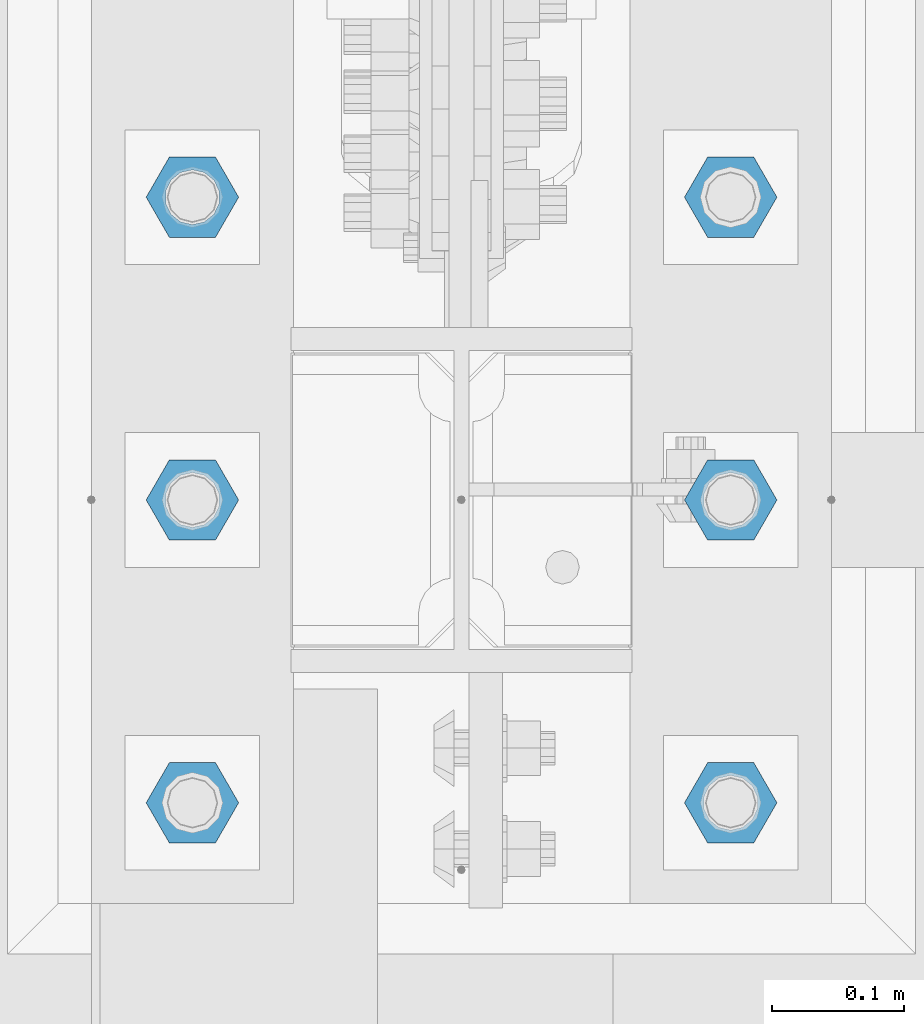
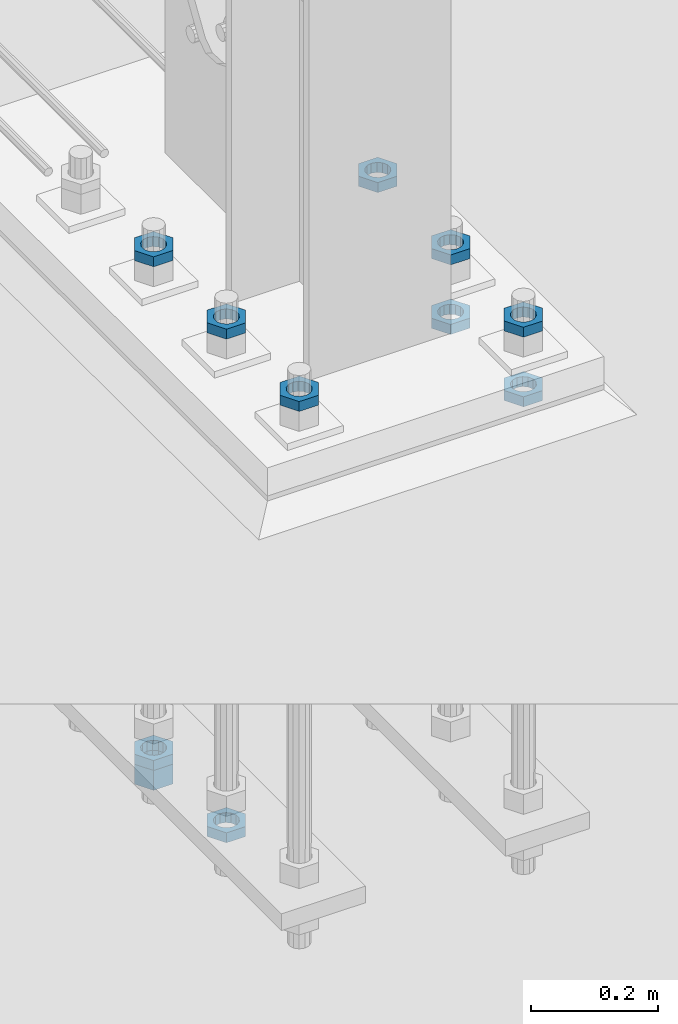
# One storey, part 2853 of 3843: 11 beams, 1 element without a shape of its own.
"""IFC2X3 building model written with IfcOpenShell, lengths in millimetres."""

from ifc_helpers import new_model, si_unit, frame, origin_with_axes, place, context, subcontext, project, spatial, faceted_brep, material, type_object, element, aggregate, save


model = new_model("IFC2X3")

# Units and contexts
model_context = context("Model", 3, precision=1e-05, world=origin_with_axes())
body_context = subcontext(model_context, "Body", "Model", "MODEL_VIEW")
ifc_project = project(units=[si_unit("LENGTHUNIT", "METRE", prefix="MILLI"), si_unit("AREAUNIT", "SQUARE_METRE"), si_unit("VOLUMEUNIT", "CUBIC_METRE"), si_unit("MASSUNIT", "GRAM", prefix="KILO"), si_unit("TIMEUNIT", "SECOND"), si_unit("PLANEANGLEUNIT", "RADIAN"), si_unit("SOLIDANGLEUNIT", "STERADIAN"), si_unit("THERMODYNAMICTEMPERATUREUNIT", "DEGREE_CELSIUS"), si_unit("LUMINOUSINTENSITYUNIT", "LUMEN")], contexts=[model_context])

# Site, building, storey
site_placement = place(None, origin_with_axes())
site = spatial("IfcSite", under=ifc_project, at=site_placement, CompositionType="ELEMENT")
building_placement = place(site_placement, origin_with_axes())
building = spatial("IfcBuilding", under=site, at=building_placement, Name="Undefined", CompositionType="ELEMENT")
storey_placement = place(building_placement, origin_with_axes())
storey = spatial("IfcBuildingStorey", under=building, at=storey_placement, Name="Undefined", CompositionType="ELEMENT", Elevation=0.0)

# Assembly, beams
assembly_placement = place(storey_placement, origin_with_axes())
assembly = element("IfcElementAssembly", 1, at=assembly_placement, inside=storey, Name="TEMPLATE", AssemblyPlace="NOTDEFINED", PredefinedType="RIGID_FRAME")
ifc_material = material(Name="STEEL/A572-50")
beam_type_1 = type_object("IfcBeamType", Name="1-1/2_HEAVY_HEX_NUT", PredefinedType="NOTDEFINED")
beam_1_placement = place(assembly_placement, frame((-203.2, 96710.5000048842, 28905.2), z_axis=(0.0, -1.0, 0.0), x_axis=(0.0, 0.0, -1.0)))
beam_1 = element("IfcBeam", 2, at=beam_1_placement, type_object=beam_type_1, material=ifc_material, Name="NUT", ObjectType="1-1/2_HEAVY_HEX_NUT", context=body_context, shape_type="Brep", body=[
    faceted_brep([(0.0, -34.9199981689453, 0.0), (0.0, -17.4599990844727, -30.25), (38.0999999999985, -17.4599990844727, -30.25), (38.0999999999985, -34.9199981689453, 0.0), (0.0, 17.4599990844727, -30.25), (38.0999999999985, 17.4599990844727, -30.25), (0.0, 34.9199981689453, 0.0), (38.0999999999985, 34.9199981689453, 0.0), (0.0, 17.4599990844727, 30.25), (38.0999999999985, 17.4599990844727, 30.25), (0.0, -17.4599990844727, 30.25), (38.0999999999985, -17.4599990844727, 30.25), (0.0, 0.0, 20.6399993896484), (0.0, 8.9553601105581, 18.5959968835959), (38.0999999999985, 8.9553601105581, 18.5959968835959), (38.0999999999985, 0.0, 20.6399993896484), (0.0, 16.1370013209525, 12.8688291298167), (38.0999999999985, 16.1370013209525, 12.8688291298167), (0.0, 20.1225115123816, 4.59283194104501), (38.0999999999985, 20.1225115123816, 4.59283194104501), (0.0, 20.1225115123816, -4.59283194104501), (38.0999999999985, 20.1225115123816, -4.59283194104501), (0.0, 16.1370013209525, -12.8688291298167), (38.0999999999985, 16.1370013209525, -12.8688291298167), (0.0, 8.9553601105581, -18.5959968835959), (38.0999999999985, 8.9553601105581, -18.5959968835959), (0.0, 0.0, -20.6399993896484), (38.0999999999985, 0.0, -20.6399993896484), (0.0, -8.9553601105581, -18.5959968835959), (38.0999999999985, -8.9553601105581, -18.5959968835959), (0.0, -16.1370013209525, -12.8688291298167), (38.0999999999985, -16.1370013209525, -12.8688291298167), (0.0, -20.1225115123816, -4.59283194104501), (38.0999999999985, -20.1225115123816, -4.59283194104501), (0.0, -20.1225115123816, 4.59283194104501), (38.0999999999985, -20.1225115123816, 4.59283194104501), (0.0, -16.1370013209525, 12.8688291298167), (38.0999999999985, -16.1370013209525, 12.8688291298167), (0.0, -8.9553601105581, 18.5959968835959), (38.0999999999985, -8.9553601105581, 18.5959968835959)], [[[0, 1, 2, 3]], [[1, 4, 5, 2]], [[4, 6, 7, 5]], [[6, 8, 9, 7]], [[8, 10, 11, 9]], [[10, 0, 3, 11]], [[12, 13, 14, 15]], [[13, 16, 17, 14]], [[16, 18, 19, 17]], [[18, 20, 21, 19]], [[20, 22, 23, 21]], [[22, 24, 25, 23]], [[24, 26, 27, 25]], [[26, 28, 29, 27]], [[28, 30, 31, 29]], [[30, 32, 33, 31]], [[32, 34, 35, 33]], [[34, 36, 37, 35]], [[36, 38, 39, 37]], [[38, 12, 15, 39]], [[5, 7, 9, 11, 3, 2], [17, 19, 21, 23, 25, 27, 29, 31, 33, 35, 37, 39, 15, 14]], [[10, 8, 6, 4, 1, 0], [38, 36, 34, 32, 30, 28, 26, 24, 22, 20, 18, 16, 13, 12]]]),
])
beam_type_2 = type_object("IfcBeamType", Name="1-1/2_HALF_NUT", PredefinedType="NOTDEFINED")
beam_2_placement = place(assembly_placement, frame((203.2, 96481.9000244154, 29756.1), z_axis=(0.0, 1.0, 0.0), x_axis=(0.0, 0.0, -1.0)))
beam_2 = element("IfcBeam", 3, at=beam_2_placement, type_object=beam_type_2, material=ifc_material, Name="NUT", ObjectType="1-1/2_HALF_NUT", context=body_context, shape_type="Brep", body=[
    faceted_brep([(0.0, -34.9199981689453, 0.0), (0.0, -17.4599990844727, -30.25), (19.0500000000029, -17.4599990844727, -30.25), (19.0500000000029, -34.9199981689453, 0.0), (0.0, 17.4599990844727, -30.25), (19.0500000000029, 17.4599990844727, -30.25), (0.0, 34.9199981689453, 0.0), (19.0500000000029, 34.9199981689453, 0.0), (0.0, 17.4599990844727, 30.25), (19.0500000000029, 17.4599990844727, 30.25), (0.0, -17.4599990844727, 30.25), (19.0500000000029, -17.4599990844727, 30.25), (0.0, 0.0, 20.6399993896484), (0.0, 8.9553601105581, 18.5959968835959), (19.0500000000029, 8.95536011056538, 18.5959968835959), (19.0500000000029, 0.0, 20.6399993896484), (0.0, 16.1370013209525, 12.8688291298167), (19.0500000000029, 16.1370013209489, 12.8688291298167), (0.0, 20.1225115123816, 4.59283194104501), (19.0500000000029, 20.1225115123852, 4.59283194104501), (0.0, 20.1225115123816, -4.59283194104501), (19.0500000000029, 20.1225115123852, -4.59283194104501), (0.0, 16.1370013209525, -12.8688291298167), (19.0500000000029, 16.1370013209489, -12.8688291298167), (0.0, 8.9553601105581, -18.5959968835959), (19.0500000000029, 8.95536011056538, -18.5959968835959), (0.0, 0.0, -20.6399993896484), (19.0500000000029, 0.0, -20.6399993896484), (0.0, -8.9553601105581, -18.5959968835959), (19.0500000000029, -8.95536011056538, -18.5959968835959), (0.0, -16.1370013209525, -12.8688291298167), (19.0500000000029, -16.1370013209489, -12.8688291298167), (0.0, -20.1225115123816, -4.59283194104501), (19.0500000000029, -20.1225115123852, -4.59283194104501), (0.0, -20.1225115123816, 4.59283194104501), (19.0500000000029, -20.1225115123852, 4.59283194104501), (0.0, -16.1370013209525, 12.8688291298167), (19.0500000000029, -16.1370013209489, 12.8688291298167), (0.0, -8.9553601105581, 18.5959968835959), (19.0500000000029, -8.95536011056538, 18.5959968835959)], [[[0, 1, 2, 3]], [[1, 4, 5, 2]], [[4, 6, 7, 5]], [[6, 8, 9, 7]], [[8, 10, 11, 9]], [[10, 0, 3, 11]], [[12, 13, 14, 15]], [[13, 16, 17, 14]], [[16, 18, 19, 17]], [[18, 20, 21, 19]], [[20, 22, 23, 21]], [[22, 24, 25, 23]], [[24, 26, 27, 25]], [[26, 28, 29, 27]], [[28, 30, 31, 29]], [[30, 32, 33, 31]], [[32, 34, 35, 33]], [[34, 36, 37, 35]], [[36, 38, 39, 37]], [[38, 12, 15, 39]], [[5, 7, 9, 11, 3, 2], [17, 19, 21, 23, 25, 27, 29, 31, 33, 35, 37, 39, 15, 14]], [[10, 8, 6, 4, 1, 0], [38, 36, 34, 32, 30, 28, 26, 24, 22, 20, 18, 16, 13, 12]]]),
])
beam_3_placement = place(assembly_placement, frame((203.2, 96253.3000244154, 29756.1), z_axis=(0.0, 1.0, 0.0), x_axis=(0.0, 0.0, -1.0)))
beam_3 = element("IfcBeam", 4, at=beam_3_placement, type_object=beam_type_2, material=ifc_material, Name="NUT", ObjectType="1-1/2_HALF_NUT", context=body_context, shape_type="Brep", body=[
    faceted_brep([(0.0, -34.9199981689453, 0.0), (0.0, -17.4599990844727, -30.25), (19.0500000000029, -17.4599990844727, -30.25), (19.0500000000029, -34.9199981689453, 0.0), (0.0, 17.4599990844727, -30.25), (19.0500000000029, 17.4599990844727, -30.25), (0.0, 34.9199981689453, 0.0), (19.0500000000029, 34.9199981689453, 0.0), (0.0, 17.4599990844727, 30.25), (19.0500000000029, 17.4599990844727, 30.25), (0.0, -17.4599990844727, 30.25), (19.0500000000029, -17.4599990844727, 30.25), (0.0, 0.0, 20.6399993896484), (0.0, 8.9553601105581, 18.5959968835959), (19.0500000000029, 8.95536011056538, 18.5959968835959), (19.0500000000029, 0.0, 20.6399993896484), (0.0, 16.1370013209525, 12.8688291298167), (19.0500000000029, 16.1370013209489, 12.8688291298167), (0.0, 20.1225115123816, 4.59283194104501), (19.0500000000029, 20.1225115123852, 4.59283194104501), (0.0, 20.1225115123816, -4.59283194104501), (19.0500000000029, 20.1225115123852, -4.59283194104501), (0.0, 16.1370013209525, -12.8688291298167), (19.0500000000029, 16.1370013209489, -12.8688291298167), (0.0, 8.9553601105581, -18.5959968835959), (19.0500000000029, 8.95536011056538, -18.5959968835959), (0.0, 0.0, -20.6399993896484), (19.0500000000029, 0.0, -20.6399993896484), (0.0, -8.9553601105581, -18.5959968835959), (19.0500000000029, -8.95536011056538, -18.5959968835959), (0.0, -16.1370013209525, -12.8688291298167), (19.0500000000029, -16.1370013209489, -12.8688291298167), (0.0, -20.1225115123816, -4.59283194104501), (19.0500000000029, -20.1225115123852, -4.59283194104501), (0.0, -20.1225115123816, 4.59283194104501), (19.0500000000029, -20.1225115123852, 4.59283194104501), (0.0, -16.1370013209525, 12.8688291298167), (19.0500000000029, -16.1370013209489, 12.8688291298167), (0.0, -8.9553601105581, 18.5959968835959), (19.0500000000029, -8.95536011056538, 18.5959968835959)], [[[0, 1, 2, 3]], [[1, 4, 5, 2]], [[4, 6, 7, 5]], [[6, 8, 9, 7]], [[8, 10, 11, 9]], [[10, 0, 3, 11]], [[12, 13, 14, 15]], [[13, 16, 17, 14]], [[16, 18, 19, 17]], [[18, 20, 21, 19]], [[20, 22, 23, 21]], [[22, 24, 25, 23]], [[24, 26, 27, 25]], [[26, 28, 29, 27]], [[28, 30, 31, 29]], [[30, 32, 33, 31]], [[32, 34, 35, 33]], [[34, 36, 37, 35]], [[36, 38, 39, 37]], [[38, 12, 15, 39]], [[5, 7, 9, 11, 3, 2], [17, 19, 21, 23, 25, 27, 29, 31, 33, 35, 37, 39, 15, 14]], [[10, 8, 6, 4, 1, 0], [38, 36, 34, 32, 30, 28, 26, 24, 22, 20, 18, 16, 13, 12]]]),
])
beam_4_placement = place(assembly_placement, frame((-203.2, 96710.5000000014, 29889.45), z_axis=(0.0, -1.0, 0.0), x_axis=(0.0, 0.0, -1.0)))
beam_4 = element("IfcBeam", 5, at=beam_4_placement, type_object=beam_type_2, material=ifc_material, Name="NUT", ObjectType="1-1/2_HALF_NUT", context=body_context, shape_type="Brep", body=[
    faceted_brep([(0.0, -34.9199981689453, 0.0), (0.0, -17.4599990844727, -30.25), (19.0500000000029, -17.4599990844727, -30.25), (19.0500000000029, -34.9199981689453, 0.0), (0.0, 17.4599990844727, -30.25), (19.0500000000029, 17.4599990844727, -30.25), (0.0, 34.9199981689453, 0.0), (19.0500000000029, 34.9199981689453, 0.0), (0.0, 17.4599990844727, 30.25), (19.0500000000029, 17.4599990844727, 30.25), (0.0, -17.4599990844727, 30.25), (19.0500000000029, -17.4599990844727, 30.25), (0.0, 0.0, 20.6399993896484), (0.0, 8.9553601105581, 18.5959968835959), (19.0500000000029, 8.95536011056538, 18.5959968835959), (19.0500000000029, 0.0, 20.6399993896484), (0.0, 16.1370013209525, 12.8688291298167), (19.0500000000029, 16.1370013209489, 12.8688291298167), (0.0, 20.1225115123816, 4.59283194104501), (19.0500000000029, 20.1225115123852, 4.59283194104501), (0.0, 20.1225115123816, -4.59283194104501), (19.0500000000029, 20.1225115123852, -4.59283194104501), (0.0, 16.1370013209525, -12.8688291298167), (19.0500000000029, 16.1370013209489, -12.8688291298167), (0.0, 8.9553601105581, -18.5959968835959), (19.0500000000029, 8.95536011056538, -18.5959968835959), (0.0, 0.0, -20.6399993896484), (19.0500000000029, 0.0, -20.6399993896484), (0.0, -8.9553601105581, -18.5959968835959), (19.0500000000029, -8.95536011056538, -18.5959968835959), (0.0, -16.1370013209525, -12.8688291298167), (19.0500000000029, -16.1370013209489, -12.8688291298167), (0.0, -20.1225115123816, -4.59283194104501), (19.0500000000029, -20.1225115123852, -4.59283194104501), (0.0, -20.1225115123816, 4.59283194104501), (19.0500000000029, -20.1225115123852, 4.59283194104501), (0.0, -16.1370013209525, 12.8688291298167), (19.0500000000029, -16.1370013209489, 12.8688291298167), (0.0, -8.9553601105581, 18.5959968835959), (19.0500000000029, -8.95536011056538, 18.5959968835959)], [[[0, 1, 2, 3]], [[1, 4, 5, 2]], [[4, 6, 7, 5]], [[6, 8, 9, 7]], [[8, 10, 11, 9]], [[10, 0, 3, 11]], [[12, 13, 14, 15]], [[13, 16, 17, 14]], [[16, 18, 19, 17]], [[18, 20, 21, 19]], [[20, 22, 23, 21]], [[22, 24, 25, 23]], [[24, 26, 27, 25]], [[26, 28, 29, 27]], [[28, 30, 31, 29]], [[30, 32, 33, 31]], [[32, 34, 35, 33]], [[34, 36, 37, 35]], [[36, 38, 39, 37]], [[38, 12, 15, 39]], [[5, 7, 9, 11, 3, 2], [17, 19, 21, 23, 25, 27, 29, 31, 33, 35, 37, 39, 15, 14]], [[10, 8, 6, 4, 1, 0], [38, 36, 34, 32, 30, 28, 26, 24, 22, 20, 18, 16, 13, 12]]]),
])
beam_5_placement = place(assembly_placement, frame((-203.2, 96481.9000000014, 29889.45), z_axis=(0.0, -1.0, 0.0), x_axis=(0.0, 0.0, -1.0)))
beam_5 = element("IfcBeam", 6, at=beam_5_placement, type_object=beam_type_2, material=ifc_material, Name="NUT", ObjectType="1-1/2_HALF_NUT", context=body_context, shape_type="Brep", body=[
    faceted_brep([(0.0, -34.9199981689453, 0.0), (0.0, -17.4599990844727, -30.25), (19.0500000000029, -17.4599990844727, -30.25), (19.0500000000029, -34.9199981689453, 0.0), (0.0, 17.4599990844727, -30.25), (19.0500000000029, 17.4599990844727, -30.25), (0.0, 34.9199981689453, 0.0), (19.0500000000029, 34.9199981689453, 0.0), (0.0, 17.4599990844727, 30.25), (19.0500000000029, 17.4599990844727, 30.25), (0.0, -17.4599990844727, 30.25), (19.0500000000029, -17.4599990844727, 30.25), (0.0, 0.0, 20.6399993896484), (0.0, 8.9553601105581, 18.5959968835959), (19.0500000000029, 8.95536011056538, 18.5959968835959), (19.0500000000029, 0.0, 20.6399993896484), (0.0, 16.1370013209525, 12.8688291298167), (19.0500000000029, 16.1370013209489, 12.8688291298167), (0.0, 20.1225115123816, 4.59283194104501), (19.0500000000029, 20.1225115123852, 4.59283194104501), (0.0, 20.1225115123816, -4.59283194104501), (19.0500000000029, 20.1225115123852, -4.59283194104501), (0.0, 16.1370013209525, -12.8688291298167), (19.0500000000029, 16.1370013209489, -12.8688291298167), (0.0, 8.9553601105581, -18.5959968835959), (19.0500000000029, 8.95536011056538, -18.5959968835959), (0.0, 0.0, -20.6399993896484), (19.0500000000029, 0.0, -20.6399993896484), (0.0, -8.9553601105581, -18.5959968835959), (19.0500000000029, -8.95536011056538, -18.5959968835959), (0.0, -16.1370013209525, -12.8688291298167), (19.0500000000029, -16.1370013209489, -12.8688291298167), (0.0, -20.1225115123816, -4.59283194104501), (19.0500000000029, -20.1225115123852, -4.59283194104501), (0.0, -20.1225115123816, 4.59283194104501), (19.0500000000029, -20.1225115123852, 4.59283194104501), (0.0, -16.1370013209525, 12.8688291298167), (19.0500000000029, -16.1370013209489, 12.8688291298167), (0.0, -8.9553601105581, 18.5959968835959), (19.0500000000029, -8.95536011056538, 18.5959968835959)], [[[0, 1, 2, 3]], [[1, 4, 5, 2]], [[4, 6, 7, 5]], [[6, 8, 9, 7]], [[8, 10, 11, 9]], [[10, 0, 3, 11]], [[12, 13, 14, 15]], [[13, 16, 17, 14]], [[16, 18, 19, 17]], [[18, 20, 21, 19]], [[20, 22, 23, 21]], [[22, 24, 25, 23]], [[24, 26, 27, 25]], [[26, 28, 29, 27]], [[28, 30, 31, 29]], [[30, 32, 33, 31]], [[32, 34, 35, 33]], [[34, 36, 37, 35]], [[36, 38, 39, 37]], [[38, 12, 15, 39]], [[5, 7, 9, 11, 3, 2], [17, 19, 21, 23, 25, 27, 29, 31, 33, 35, 37, 39, 15, 14]], [[10, 8, 6, 4, 1, 0], [38, 36, 34, 32, 30, 28, 26, 24, 22, 20, 18, 16, 13, 12]]]),
])
beam_6_placement = place(assembly_placement, frame((-203.2, 96253.3000000014, 29889.45), z_axis=(0.0, -1.0, 0.0), x_axis=(0.0, 0.0, -1.0)))
beam_6 = element("IfcBeam", 7, at=beam_6_placement, type_object=beam_type_2, material=ifc_material, Name="NUT", ObjectType="1-1/2_HALF_NUT", context=body_context, shape_type="Brep", body=[
    faceted_brep([(0.0, -34.9199981689453, 0.0), (0.0, -17.4599990844727, -30.25), (19.0500000000029, -17.4599990844727, -30.25), (19.0500000000029, -34.9199981689453, 0.0), (0.0, 17.4599990844727, -30.25), (19.0500000000029, 17.4599990844727, -30.25), (0.0, 34.9199981689453, 0.0), (19.0500000000029, 34.9199981689453, 0.0), (0.0, 17.4599990844727, 30.25), (19.0500000000029, 17.4599990844727, 30.25), (0.0, -17.4599990844727, 30.25), (19.0500000000029, -17.4599990844727, 30.25), (0.0, 0.0, 20.6399993896484), (0.0, 8.9553601105581, 18.5959968835959), (19.0500000000029, 8.95536011056538, 18.5959968835959), (19.0500000000029, 0.0, 20.6399993896484), (0.0, 16.1370013209525, 12.8688291298167), (19.0500000000029, 16.1370013209489, 12.8688291298167), (0.0, 20.1225115123816, 4.59283194104501), (19.0500000000029, 20.1225115123852, 4.59283194104501), (0.0, 20.1225115123816, -4.59283194104501), (19.0500000000029, 20.1225115123852, -4.59283194104501), (0.0, 16.1370013209525, -12.8688291298167), (19.0500000000029, 16.1370013209489, -12.8688291298167), (0.0, 8.9553601105581, -18.5959968835959), (19.0500000000029, 8.95536011056538, -18.5959968835959), (0.0, 0.0, -20.6399993896484), (19.0500000000029, 0.0, -20.6399993896484), (0.0, -8.9553601105581, -18.5959968835959), (19.0500000000029, -8.95536011056538, -18.5959968835959), (0.0, -16.1370013209525, -12.8688291298167), (19.0500000000029, -16.1370013209489, -12.8688291298167), (0.0, -20.1225115123816, -4.59283194104501), (19.0500000000029, -20.1225115123852, -4.59283194104501), (0.0, -20.1225115123816, 4.59283194104501), (19.0500000000029, -20.1225115123852, 4.59283194104501), (0.0, -16.1370013209525, 12.8688291298167), (19.0500000000029, -16.1370013209489, 12.8688291298167), (0.0, -8.9553601105581, 18.5959968835959), (19.0500000000029, -8.95536011056538, 18.5959968835959)], [[[0, 1, 2, 3]], [[1, 4, 5, 2]], [[4, 6, 7, 5]], [[6, 8, 9, 7]], [[8, 10, 11, 9]], [[10, 0, 3, 11]], [[12, 13, 14, 15]], [[13, 16, 17, 14]], [[16, 18, 19, 17]], [[18, 20, 21, 19]], [[20, 22, 23, 21]], [[22, 24, 25, 23]], [[24, 26, 27, 25]], [[26, 28, 29, 27]], [[28, 30, 31, 29]], [[30, 32, 33, 31]], [[32, 34, 35, 33]], [[34, 36, 37, 35]], [[36, 38, 39, 37]], [[38, 12, 15, 39]], [[5, 7, 9, 11, 3, 2], [17, 19, 21, 23, 25, 27, 29, 31, 33, 35, 37, 39, 15, 14]], [[10, 8, 6, 4, 1, 0], [38, 36, 34, 32, 30, 28, 26, 24, 22, 20, 18, 16, 13, 12]]]),
])
beam_7_placement = place(assembly_placement, frame((203.2, 96710.5000244154, 29889.45), z_axis=(0.0, 1.0, 0.0), x_axis=(0.0, 0.0, -1.0)))
beam_7 = element("IfcBeam", 8, at=beam_7_placement, type_object=beam_type_2, material=ifc_material, Name="NUT", ObjectType="1-1/2_HALF_NUT", context=body_context, shape_type="Brep", body=[
    faceted_brep([(0.0, -34.9199981689453, 0.0), (0.0, -17.4599990844727, -30.25), (19.0500000000029, -17.4599990844727, -30.25), (19.0500000000029, -34.9199981689453, 0.0), (0.0, 17.4599990844727, -30.25), (19.0500000000029, 17.4599990844727, -30.25), (0.0, 34.9199981689453, 0.0), (19.0500000000029, 34.9199981689453, 0.0), (0.0, 17.4599990844727, 30.25), (19.0500000000029, 17.4599990844727, 30.25), (0.0, -17.4599990844727, 30.25), (19.0500000000029, -17.4599990844727, 30.25), (0.0, 0.0, 20.6399993896484), (0.0, 8.9553601105581, 18.5959968835959), (19.0500000000029, 8.95536011056538, 18.5959968835959), (19.0500000000029, 0.0, 20.6399993896484), (0.0, 16.1370013209525, 12.8688291298167), (19.0500000000029, 16.1370013209489, 12.8688291298167), (0.0, 20.1225115123816, 4.59283194104501), (19.0500000000029, 20.1225115123852, 4.59283194104501), (0.0, 20.1225115123816, -4.59283194104501), (19.0500000000029, 20.1225115123852, -4.59283194104501), (0.0, 16.1370013209525, -12.8688291298167), (19.0500000000029, 16.1370013209489, -12.8688291298167), (0.0, 8.9553601105581, -18.5959968835959), (19.0500000000029, 8.95536011056538, -18.5959968835959), (0.0, 0.0, -20.6399993896484), (19.0500000000029, 0.0, -20.6399993896484), (0.0, -8.9553601105581, -18.5959968835959), (19.0500000000029, -8.95536011056538, -18.5959968835959), (0.0, -16.1370013209525, -12.8688291298167), (19.0500000000029, -16.1370013209489, -12.8688291298167), (0.0, -20.1225115123816, -4.59283194104501), (19.0500000000029, -20.1225115123852, -4.59283194104501), (0.0, -20.1225115123816, 4.59283194104501), (19.0500000000029, -20.1225115123852, 4.59283194104501), (0.0, -16.1370013209525, 12.8688291298167), (19.0500000000029, -16.1370013209489, 12.8688291298167), (0.0, -8.9553601105581, 18.5959968835959), (19.0500000000029, -8.95536011056538, 18.5959968835959)], [[[0, 1, 2, 3]], [[1, 4, 5, 2]], [[4, 6, 7, 5]], [[6, 8, 9, 7]], [[8, 10, 11, 9]], [[10, 0, 3, 11]], [[12, 13, 14, 15]], [[13, 16, 17, 14]], [[16, 18, 19, 17]], [[18, 20, 21, 19]], [[20, 22, 23, 21]], [[22, 24, 25, 23]], [[24, 26, 27, 25]], [[26, 28, 29, 27]], [[28, 30, 31, 29]], [[30, 32, 33, 31]], [[32, 34, 35, 33]], [[34, 36, 37, 35]], [[36, 38, 39, 37]], [[38, 12, 15, 39]], [[5, 7, 9, 11, 3, 2], [17, 19, 21, 23, 25, 27, 29, 31, 33, 35, 37, 39, 15, 14]], [[10, 8, 6, 4, 1, 0], [38, 36, 34, 32, 30, 28, 26, 24, 22, 20, 18, 16, 13, 12]]]),
])
beam_8_placement = place(assembly_placement, frame((203.2, 96481.9000244154, 29889.45), z_axis=(0.0, 1.0, 0.0), x_axis=(0.0, 0.0, -1.0)))
beam_8 = element("IfcBeam", 9, at=beam_8_placement, type_object=beam_type_2, material=ifc_material, Name="NUT", ObjectType="1-1/2_HALF_NUT", context=body_context, shape_type="Brep", body=[
    faceted_brep([(0.0, -34.9199981689453, 0.0), (0.0, -17.4599990844727, -30.25), (19.0500000000029, -17.4599990844727, -30.25), (19.0500000000029, -34.9199981689453, 0.0), (0.0, 17.4599990844727, -30.25), (19.0500000000029, 17.4599990844727, -30.25), (0.0, 34.9199981689453, 0.0), (19.0500000000029, 34.9199981689453, 0.0), (0.0, 17.4599990844727, 30.25), (19.0500000000029, 17.4599990844727, 30.25), (0.0, -17.4599990844727, 30.25), (19.0500000000029, -17.4599990844727, 30.25), (0.0, 0.0, 20.6399993896484), (0.0, 8.9553601105581, 18.5959968835959), (19.0500000000029, 8.95536011056538, 18.5959968835959), (19.0500000000029, 0.0, 20.6399993896484), (0.0, 16.1370013209525, 12.8688291298167), (19.0500000000029, 16.1370013209489, 12.8688291298167), (0.0, 20.1225115123816, 4.59283194104501), (19.0500000000029, 20.1225115123852, 4.59283194104501), (0.0, 20.1225115123816, -4.59283194104501), (19.0500000000029, 20.1225115123852, -4.59283194104501), (0.0, 16.1370013209525, -12.8688291298167), (19.0500000000029, 16.1370013209489, -12.8688291298167), (0.0, 8.9553601105581, -18.5959968835959), (19.0500000000029, 8.95536011056538, -18.5959968835959), (0.0, 0.0, -20.6399993896484), (19.0500000000029, 0.0, -20.6399993896484), (0.0, -8.9553601105581, -18.5959968835959), (19.0500000000029, -8.95536011056538, -18.5959968835959), (0.0, -16.1370013209525, -12.8688291298167), (19.0500000000029, -16.1370013209489, -12.8688291298167), (0.0, -20.1225115123816, -4.59283194104501), (19.0500000000029, -20.1225115123852, -4.59283194104501), (0.0, -20.1225115123816, 4.59283194104501), (19.0500000000029, -20.1225115123852, 4.59283194104501), (0.0, -16.1370013209525, 12.8688291298167), (19.0500000000029, -16.1370013209489, 12.8688291298167), (0.0, -8.9553601105581, 18.5959968835959), (19.0500000000029, -8.95536011056538, 18.5959968835959)], [[[0, 1, 2, 3]], [[1, 4, 5, 2]], [[4, 6, 7, 5]], [[6, 8, 9, 7]], [[8, 10, 11, 9]], [[10, 0, 3, 11]], [[12, 13, 14, 15]], [[13, 16, 17, 14]], [[16, 18, 19, 17]], [[18, 20, 21, 19]], [[20, 22, 23, 21]], [[22, 24, 25, 23]], [[24, 26, 27, 25]], [[26, 28, 29, 27]], [[28, 30, 31, 29]], [[30, 32, 33, 31]], [[32, 34, 35, 33]], [[34, 36, 37, 35]], [[36, 38, 39, 37]], [[38, 12, 15, 39]], [[5, 7, 9, 11, 3, 2], [17, 19, 21, 23, 25, 27, 29, 31, 33, 35, 37, 39, 15, 14]], [[10, 8, 6, 4, 1, 0], [38, 36, 34, 32, 30, 28, 26, 24, 22, 20, 18, 16, 13, 12]]]),
])
beam_9_placement = place(assembly_placement, frame((203.2, 96253.3000244154, 29889.45), z_axis=(0.0, 1.0, 0.0), x_axis=(0.0, 0.0, -1.0)))
beam_9 = element("IfcBeam", 10, at=beam_9_placement, type_object=beam_type_2, material=ifc_material, Name="NUT", ObjectType="1-1/2_HALF_NUT", context=body_context, shape_type="Brep", body=[
    faceted_brep([(0.0, -34.9199981689453, 0.0), (0.0, -17.4599990844727, -30.25), (19.0500000000029, -17.4599990844727, -30.25), (19.0500000000029, -34.9199981689453, 0.0), (0.0, 17.4599990844727, -30.25), (19.0500000000029, 17.4599990844727, -30.25), (0.0, 34.9199981689453, 0.0), (19.0500000000029, 34.9199981689453, 0.0), (0.0, 17.4599990844727, 30.25), (19.0500000000029, 17.4599990844727, 30.25), (0.0, -17.4599990844727, 30.25), (19.0500000000029, -17.4599990844727, 30.25), (0.0, 0.0, 20.6399993896484), (0.0, 8.9553601105581, 18.5959968835959), (19.0500000000029, 8.95536011056538, 18.5959968835959), (19.0500000000029, 0.0, 20.6399993896484), (0.0, 16.1370013209525, 12.8688291298167), (19.0500000000029, 16.1370013209489, 12.8688291298167), (0.0, 20.1225115123816, 4.59283194104501), (19.0500000000029, 20.1225115123852, 4.59283194104501), (0.0, 20.1225115123816, -4.59283194104501), (19.0500000000029, 20.1225115123852, -4.59283194104501), (0.0, 16.1370013209525, -12.8688291298167), (19.0500000000029, 16.1370013209489, -12.8688291298167), (0.0, 8.9553601105581, -18.5959968835959), (19.0500000000029, 8.95536011056538, -18.5959968835959), (0.0, 0.0, -20.6399993896484), (19.0500000000029, 0.0, -20.6399993896484), (0.0, -8.9553601105581, -18.5959968835959), (19.0500000000029, -8.95536011056538, -18.5959968835959), (0.0, -16.1370013209525, -12.8688291298167), (19.0500000000029, -16.1370013209489, -12.8688291298167), (0.0, -20.1225115123816, -4.59283194104501), (19.0500000000029, -20.1225115123852, -4.59283194104501), (0.0, -20.1225115123816, 4.59283194104501), (19.0500000000029, -20.1225115123852, 4.59283194104501), (0.0, -16.1370013209525, 12.8688291298167), (19.0500000000029, -16.1370013209489, 12.8688291298167), (0.0, -8.9553601105581, 18.5959968835959), (19.0500000000029, -8.95536011056538, 18.5959968835959)], [[[0, 1, 2, 3]], [[1, 4, 5, 2]], [[4, 6, 7, 5]], [[6, 8, 9, 7]], [[8, 10, 11, 9]], [[10, 0, 3, 11]], [[12, 13, 14, 15]], [[13, 16, 17, 14]], [[16, 18, 19, 17]], [[18, 20, 21, 19]], [[20, 22, 23, 21]], [[22, 24, 25, 23]], [[24, 26, 27, 25]], [[26, 28, 29, 27]], [[28, 30, 31, 29]], [[30, 32, 33, 31]], [[32, 34, 35, 33]], [[34, 36, 37, 35]], [[36, 38, 39, 37]], [[38, 12, 15, 39]], [[5, 7, 9, 11, 3, 2], [17, 19, 21, 23, 25, 27, 29, 31, 33, 35, 37, 39, 15, 14]], [[10, 8, 6, 4, 1, 0], [38, 36, 34, 32, 30, 28, 26, 24, 22, 20, 18, 16, 13, 12]]]),
])
beam_10_placement = place(assembly_placement, frame((-203.2, 96710.5000122084, 28924.25), z_axis=(0.0, -1.0, 0.0), x_axis=(0.0, 0.0, -1.0)))
beam_10 = element("IfcBeam", 11, at=beam_10_placement, type_object=beam_type_2, material=ifc_material, Name="NUT", ObjectType="1-1/2_HALF_NUT", context=body_context, shape_type="Brep", body=[
    faceted_brep([(0.0, -34.9199981689453, 0.0), (0.0, -17.4599990844727, -30.25), (19.0500000000029, -17.4599990844727, -30.25), (19.0500000000029, -34.9199981689453, 0.0), (0.0, 17.4599990844727, -30.25), (19.0500000000029, 17.4599990844727, -30.25), (0.0, 34.9199981689453, 0.0), (19.0500000000029, 34.9199981689453, 0.0), (0.0, 17.4599990844727, 30.25), (19.0500000000029, 17.4599990844727, 30.25), (0.0, -17.4599990844727, 30.25), (19.0500000000029, -17.4599990844727, 30.25), (0.0, 0.0, 20.6399993896484), (0.0, 8.9553601105581, 18.5959968835959), (19.0500000000029, 8.95536011056538, 18.5959968835959), (19.0500000000029, 0.0, 20.6399993896484), (0.0, 16.1370013209525, 12.8688291298167), (19.0500000000029, 16.1370013209489, 12.8688291298167), (0.0, 20.1225115123816, 4.59283194104501), (19.0500000000029, 20.1225115123852, 4.59283194104501), (0.0, 20.1225115123816, -4.59283194104501), (19.0500000000029, 20.1225115123852, -4.59283194104501), (0.0, 16.1370013209525, -12.8688291298167), (19.0500000000029, 16.1370013209489, -12.8688291298167), (0.0, 8.9553601105581, -18.5959968835959), (19.0500000000029, 8.95536011056538, -18.5959968835959), (0.0, 0.0, -20.6399993896484), (19.0500000000029, 0.0, -20.6399993896484), (0.0, -8.9553601105581, -18.5959968835959), (19.0500000000029, -8.95536011056538, -18.5959968835959), (0.0, -16.1370013209525, -12.8688291298167), (19.0500000000029, -16.1370013209489, -12.8688291298167), (0.0, -20.1225115123816, -4.59283194104501), (19.0500000000029, -20.1225115123852, -4.59283194104501), (0.0, -20.1225115123816, 4.59283194104501), (19.0500000000029, -20.1225115123852, 4.59283194104501), (0.0, -16.1370013209525, 12.8688291298167), (19.0500000000029, -16.1370013209489, 12.8688291298167), (0.0, -8.9553601105581, 18.5959968835959), (19.0500000000029, -8.95536011056538, 18.5959968835959)], [[[0, 1, 2, 3]], [[1, 4, 5, 2]], [[4, 6, 7, 5]], [[6, 8, 9, 7]], [[8, 10, 11, 9]], [[10, 0, 3, 11]], [[12, 13, 14, 15]], [[13, 16, 17, 14]], [[16, 18, 19, 17]], [[18, 20, 21, 19]], [[20, 22, 23, 21]], [[22, 24, 25, 23]], [[24, 26, 27, 25]], [[26, 28, 29, 27]], [[28, 30, 31, 29]], [[30, 32, 33, 31]], [[32, 34, 35, 33]], [[34, 36, 37, 35]], [[36, 38, 39, 37]], [[38, 12, 15, 39]], [[5, 7, 9, 11, 3, 2], [17, 19, 21, 23, 25, 27, 29, 31, 33, 35, 37, 39, 15, 14]], [[10, 8, 6, 4, 1, 0], [38, 36, 34, 32, 30, 28, 26, 24, 22, 20, 18, 16, 13, 12]]]),
])
beam_11_placement = place(assembly_placement, frame((-203.2, 96481.9000122084, 28924.25), z_axis=(0.0, -1.0, 0.0), x_axis=(0.0, 0.0, -1.0)))
beam_11 = element("IfcBeam", 12, at=beam_11_placement, type_object=beam_type_2, material=ifc_material, Name="NUT", ObjectType="1-1/2_HALF_NUT", context=body_context, shape_type="Brep", body=[
    faceted_brep([(0.0, -34.9199981689453, 0.0), (0.0, -17.4599990844727, -30.25), (19.0500000000029, -17.4599990844727, -30.25), (19.0500000000029, -34.9199981689453, 0.0), (0.0, 17.4599990844727, -30.25), (19.0500000000029, 17.4599990844727, -30.25), (0.0, 34.9199981689453, 0.0), (19.0500000000029, 34.9199981689453, 0.0), (0.0, 17.4599990844727, 30.25), (19.0500000000029, 17.4599990844727, 30.25), (0.0, -17.4599990844727, 30.25), (19.0500000000029, -17.4599990844727, 30.25), (0.0, 0.0, 20.6399993896484), (0.0, 8.9553601105581, 18.5959968835959), (19.0500000000029, 8.95536011056538, 18.5959968835959), (19.0500000000029, 0.0, 20.6399993896484), (0.0, 16.1370013209525, 12.8688291298167), (19.0500000000029, 16.1370013209489, 12.8688291298167), (0.0, 20.1225115123816, 4.59283194104501), (19.0500000000029, 20.1225115123852, 4.59283194104501), (0.0, 20.1225115123816, -4.59283194104501), (19.0500000000029, 20.1225115123852, -4.59283194104501), (0.0, 16.1370013209525, -12.8688291298167), (19.0500000000029, 16.1370013209489, -12.8688291298167), (0.0, 8.9553601105581, -18.5959968835959), (19.0500000000029, 8.95536011056538, -18.5959968835959), (0.0, 0.0, -20.6399993896484), (19.0500000000029, 0.0, -20.6399993896484), (0.0, -8.9553601105581, -18.5959968835959), (19.0500000000029, -8.95536011056538, -18.5959968835959), (0.0, -16.1370013209525, -12.8688291298167), (19.0500000000029, -16.1370013209489, -12.8688291298167), (0.0, -20.1225115123816, -4.59283194104501), (19.0500000000029, -20.1225115123852, -4.59283194104501), (0.0, -20.1225115123816, 4.59283194104501), (19.0500000000029, -20.1225115123852, 4.59283194104501), (0.0, -16.1370013209525, 12.8688291298167), (19.0500000000029, -16.1370013209489, 12.8688291298167), (0.0, -8.9553601105581, 18.5959968835959), (19.0500000000029, -8.95536011056538, 18.5959968835959)], [[[0, 1, 2, 3]], [[1, 4, 5, 2]], [[4, 6, 7, 5]], [[6, 8, 9, 7]], [[8, 10, 11, 9]], [[10, 0, 3, 11]], [[12, 13, 14, 15]], [[13, 16, 17, 14]], [[16, 18, 19, 17]], [[18, 20, 21, 19]], [[20, 22, 23, 21]], [[22, 24, 25, 23]], [[24, 26, 27, 25]], [[26, 28, 29, 27]], [[28, 30, 31, 29]], [[30, 32, 33, 31]], [[32, 34, 35, 33]], [[34, 36, 37, 35]], [[36, 38, 39, 37]], [[38, 12, 15, 39]], [[5, 7, 9, 11, 3, 2], [17, 19, 21, 23, 25, 27, 29, 31, 33, 35, 37, 39, 15, 14]], [[10, 8, 6, 4, 1, 0], [38, 36, 34, 32, 30, 28, 26, 24, 22, 20, 18, 16, 13, 12]]]),
])
aggregate(assembly, [beam_2, beam_3, beam_4, beam_5, beam_6, beam_7, beam_8, beam_9, beam_10, beam_1, beam_11])

save(model, "model.ifc")
